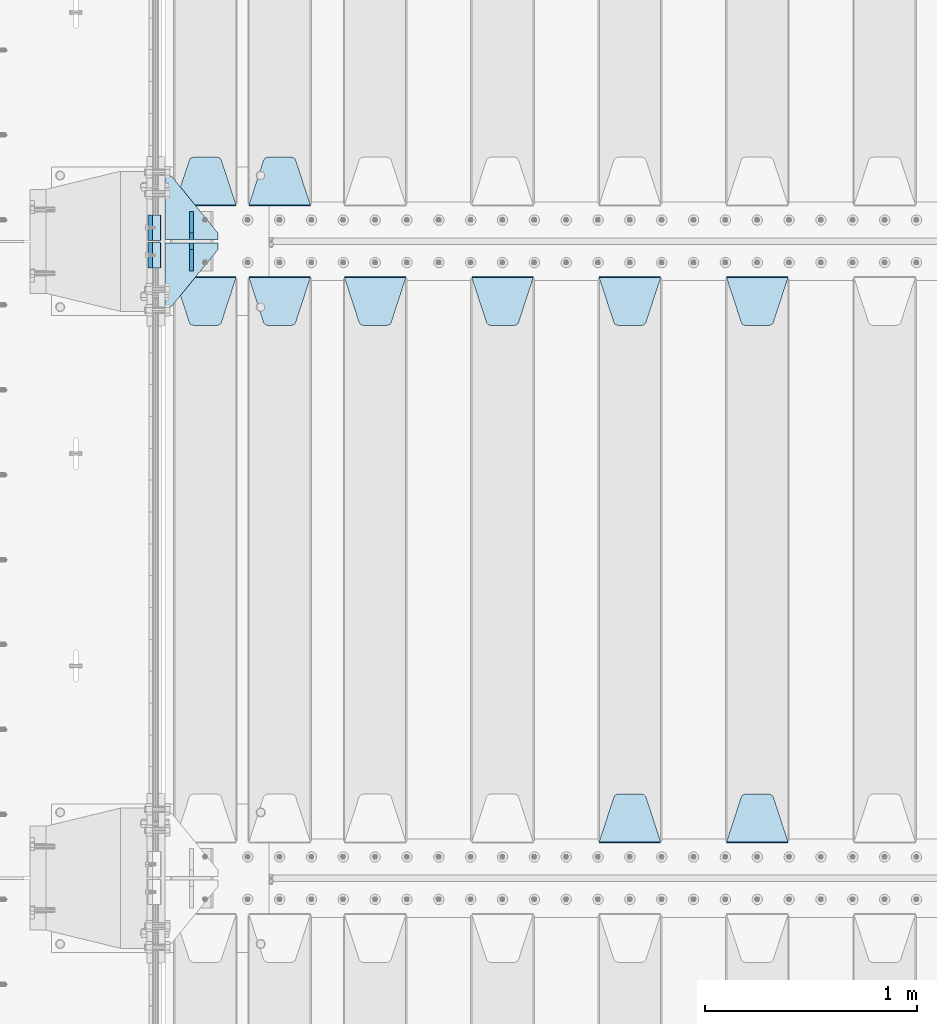
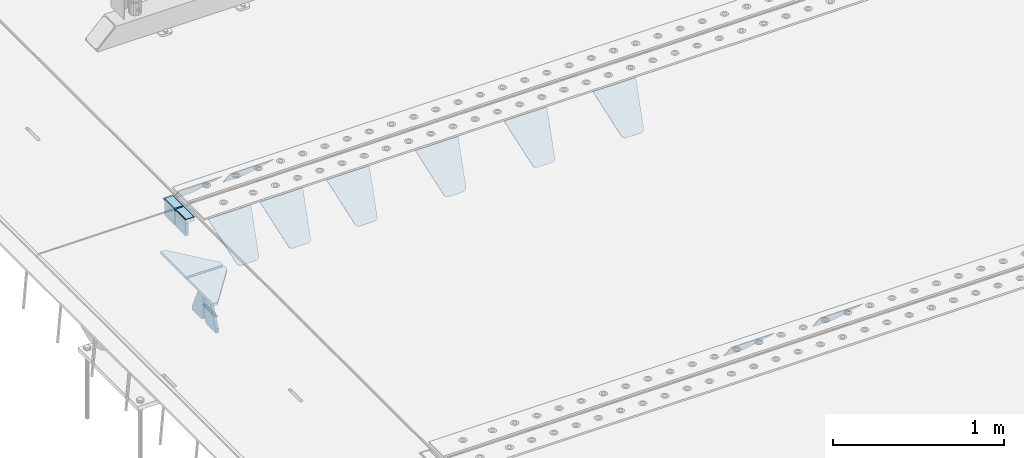
# One storey, part 200 of 247: 18 plates.
"""IFC2X3 building model written with IfcOpenShell, lengths in millimetres."""

from ifc_helpers import new_model, si_unit, frame, origin_with_axes, place, context, subcontext, project, spatial, faceted_brep, material, type_object, element, save


model = new_model("IFC2X3")

# Units and contexts
model_context = context("Model", 3, precision=1e-05, world=origin_with_axes())
body_context = subcontext(model_context, "Body", "Model", "MODEL_VIEW")
ifc_project = project(units=[si_unit("LENGTHUNIT", "METRE", prefix="MILLI"), si_unit("AREAUNIT", "SQUARE_METRE"), si_unit("VOLUMEUNIT", "CUBIC_METRE"), si_unit("MASSUNIT", "GRAM", prefix="KILO"), si_unit("TIMEUNIT", "SECOND"), si_unit("PLANEANGLEUNIT", "RADIAN"), si_unit("SOLIDANGLEUNIT", "STERADIAN"), si_unit("THERMODYNAMICTEMPERATUREUNIT", "DEGREE_CELSIUS"), si_unit("LUMINOUSINTENSITYUNIT", "LUMEN")], contexts=[model_context])

# Site, building, storey
site_placement = place(None, origin_with_axes())
site = spatial("IfcSite", under=ifc_project, at=site_placement, CompositionType="ELEMENT")
building_placement = place(site_placement, origin_with_axes())
building = spatial("IfcBuilding", under=site, at=building_placement, Name="Standard", CompositionType="ELEMENT")
storey_placement = place(building_placement, origin_with_axes())
storey = spatial("IfcBuildingStorey", under=building, at=storey_placement, Name="Undefined", CompositionType="ELEMENT", Elevation=0.0)

# Plates
ifc_material_1 = material()
plate_type_1 = type_object("IfcPlateType", PredefinedType="NOTDEFINED")
for number, where, z_axis, x_axis in (
    (1, (-9.99999993997335, 5935.0000004336, -16.0003868494704), (-1.0, 0.0, 0.0), (0.0, -4.95099999998473e-06, 0.999999999987744)),
    (2, (-10.0000000600267, 6065.00000043195, -15.999743219176), (-1.0, 0.0, 0.0), (0.0, -4.95099999998473e-06, 0.999999999987744)),
):
    element("IfcPlate", number, at=place(storey_placement, frame(where, z_axis=z_axis, x_axis=x_axis)), inside=storey, type_object=plate_type_1, material=ifc_material_1, context=body_context, shape_type="Brep", body=[
        faceted_brep([(0.0, -59.9999999999991, 0.0), (-0.000933120085690575, -60.0, 60.0), (-0.000933120085690575, 60.0, 60.0), (-3.5527136788005e-15, 60.0000000000005, 0.0), (24.9991450303709, -60.0, 60.0), (24.9991450303709, 60.0, 60.0), (26.544215218168, -60.0, 59.7552873850884), (26.544215218168, 60.0, 59.7552873850884), (27.9380461396139, -60.0, 59.0451032459123), (27.9380461396139, 60.0, 59.0451032459123), (29.0442025908961, -60.0, 57.9389639895784), (29.0442025908961, 60.0, 57.9389639895784), (29.7544083969366, -60.0, 56.5451441080361), (29.7544083969366, 60.0, 56.5451441080361), (29.9991450297669, -60.0, 55.0000777244568), (29.9991450297668, 60.0, 55.0000777244568), (29.999922274335, -60.0, 5.00007772445704), (29.999922274335, 60.0, 5.00007772445704), (29.7552240705896, -60.0, 3.45497416452589), (29.7552240705896, 60.0, 3.45497416452589), (29.0450346578116, -60.0, 2.0611114669096), (29.0450346578116, 60.0, 2.06111146690959), (27.9388736885072, -60.0, 0.954933302319514), (27.9388736885072, 60.0, 0.954933302319514), (26.5450220308766, -60.0, 0.244722222183091), (26.5450220308766, 60.0, 0.244722222183089), (24.9999222749392, -60.0, 2.66453525910038e-13), (24.9999222749392, 60.0, 2.66453525910038e-13)], [[[0, 1, 2, 3]], [[1, 4, 5, 2]], [[4, 6, 7, 5]], [[6, 8, 9, 7]], [[8, 10, 11, 9]], [[10, 12, 13, 11]], [[12, 14, 15, 13]], [[14, 16, 17, 15]], [[16, 18, 19, 17]], [[18, 20, 21, 19]], [[20, 22, 23, 21]], [[22, 24, 25, 23]], [[24, 26, 27, 25]], [[26, 0, 3, 27]], [[5, 7, 9, 11, 13, 15, 17, 19, 21, 23, 25, 27, 3, 2]], [[26, 24, 22, 20, 18, 16, 14, 12, 10, 8, 6, 4, 1, 0]]]),
    ])
ifc_material_2 = material(Name="STEEL/S355N")
plate_type_2 = type_object("IfcPlateType", PredefinedType="NOTDEFINED")
for number, where, z_axis, x_axis in (
    (3, (-60.0, 5995.00044598306, -106.000711879208), (1.00000000012752e-09, -0.999999999987744, -4.95099999993936e-06), (0.0, -4.95099999998473e-06, 0.999999999987744)),
    (4, (-60.0, 6125.00044598126, -106.000068249326), (1.00000000012752e-09, -0.999999999987744, -4.95099999993936e-06), (0.0, -4.95099999998473e-06, 0.999999999987744)),
):
    element("IfcPlate", number, at=place(storey_placement, frame(where, z_axis=z_axis, x_axis=x_axis)), inside=storey, type_object=plate_type_2, material=ifc_material_2, context=body_context, shape_type="Brep", body=[
        faceted_brep([(-5.6843418860808e-14, -9.99999999999989, 3.5527136788005e-15), (4.32933688898629e-10, -10.0, 120.0), (4.32933688898629e-10, 10.0, 120.0), (-5.6843418860808e-14, 10.0000000000001, 3.5527136788005e-15), (90.0, -10.0, 120.0), (90.0, 10.0, 120.0), (90.0, -10.0, 1.09139364212751e-11), (90.0, 10.0, 1.09139364212751e-11)], [[[0, 1, 2, 3]], [[1, 4, 5, 2]], [[4, 6, 7, 5]], [[6, 0, 3, 7]], [[5, 7, 3, 2]], [[6, 4, 1, 0]]]),
    ])
plate_type_3 = type_object("IfcPlateType", PredefinedType="NOTDEFINED")
plate_1_placement = place(storey_placement, frame((2655.0, 5831.76776695594, -1.767766952965), z_axis=(0.0, -0.707106781186548, -0.707106781186547), x_axis=(1.0, 0.0, 0.0)))
element("IfcPlate", 5, at=plate_1_placement, inside=storey, type_object=plate_type_3, material=ifc_material_2, context=body_context, shape_type="Brep", body=[
    faceted_brep([(0.0, -2.49999999999909, 0.0), (69.345504679477, -2.5, 300.17173142483), (69.345504679477, 2.50000000000091, 300.171731424831), (0.0, 2.5, -9.09494701772928e-13), (70.9274061199576, -2.5, 304.897442415399), (70.9274061199576, 2.50000000000091, 304.8974424154), (73.3818627772307, -2.49999999999909, 309.234538108527), (73.3818627772307, 2.5, 309.234538108526), (76.6187032999551, -2.5, 313.023683126102), (76.6187032999551, 2.50000000000091, 313.023683126102), (80.5190132704993, -2.49999999999909, 316.125672595371), (80.5190132704993, 2.50000000000091, 316.125672595372), (84.9395038596849, -2.49999999999909, 318.426546230476), (84.9395038596849, 2.5, 318.426546230475), (89.7177759439219, -2.5, 319.841774983274), (89.7177759439219, 2.50000000000091, 319.841774983275), (94.678286292652, -2.5, 320.319366455077), (94.678286292652, 2.50000000000091, 320.319366455077), (195.321713707348, -2.5, 320.319366455077), (195.321713707348, 2.50000000000091, 320.319366455077), (200.282224056078, -2.5, 319.841774983274), (200.282224056078, 2.50000000000091, 319.841774983275), (205.060496140315, -2.5, 318.426546230475), (205.060496140315, 2.5, 318.426546230474), (209.480986729501, -2.49999999999818, 316.12567259537), (209.480986729501, 2.50000000000091, 316.12567259537), (213.381296700045, -2.5, 313.023683126101), (213.381296700045, 2.50000000000091, 313.023683126101), (216.618137222769, -2.5, 309.234538108525), (216.618137222769, 2.5, 309.234538108525), (219.072593880042, -2.49999999999909, 304.897442415398), (219.072593880042, 2.5, 304.897442415398), (220.654495320523, -2.5, 300.17173142483), (220.654495320523, 2.50000000000091, 300.171731424831), (290.0, -2.49999999999909, 0.0), (290.0, 2.5, -9.09494701772928e-13)], [[[0, 1, 2, 3]], [[1, 4, 5, 2]], [[4, 6, 7, 5]], [[6, 8, 9, 7]], [[8, 10, 11, 9]], [[10, 12, 13, 11]], [[12, 14, 15, 13]], [[14, 16, 17, 15]], [[16, 18, 19, 17]], [[18, 20, 21, 19]], [[20, 22, 23, 21]], [[22, 24, 25, 23]], [[24, 26, 27, 25]], [[26, 28, 29, 27]], [[28, 30, 31, 29]], [[30, 32, 33, 31]], [[32, 34, 35, 33]], [[34, 0, 3, 35]], [[5, 7, 9, 11, 13, 15, 17, 19, 21, 23, 25, 27, 29, 31, 33, 35, 3, 2]], [[34, 32, 30, 28, 26, 24, 22, 20, 18, 16, 14, 12, 10, 8, 6, 4, 1, 0]]]),
])
plate_2_placement = place(storey_placement, frame((2945.0, 3168.23223304703, -1.76776695296758), z_axis=(0.0, 0.707106781186548, -0.707106781186547), x_axis=(-1.0, 0.0, 0.0)))
element("IfcPlate", 6, at=plate_2_placement, inside=storey, type_object=plate_type_3, material=ifc_material_2, context=body_context, shape_type="Brep", body=[
    faceted_brep([(0.0, -2.49999999999909, 0.0), (69.345504679477, -2.5, 300.17173142483), (69.345504679477, 2.50000000000091, 300.171731424831), (0.0, 2.5, -9.09494701772928e-13), (70.9274061199576, -2.5, 304.897442415399), (70.9274061199576, 2.50000000000091, 304.8974424154), (73.3818627772307, -2.49999999999909, 309.234538108527), (73.3818627772307, 2.5, 309.234538108526), (76.6187032999551, -2.5, 313.023683126102), (76.6187032999551, 2.50000000000091, 313.023683126102), (80.5190132704993, -2.49999999999909, 316.125672595371), (80.5190132704993, 2.50000000000091, 316.125672595372), (84.9395038596849, -2.49999999999909, 318.426546230476), (84.9395038596849, 2.5, 318.426546230475), (89.7177759439219, -2.5, 319.841774983274), (89.7177759439219, 2.50000000000091, 319.841774983275), (94.678286292652, -2.5, 320.319366455077), (94.678286292652, 2.50000000000091, 320.319366455077), (195.321713707348, -2.5, 320.319366455077), (195.321713707348, 2.50000000000091, 320.319366455077), (200.282224056078, -2.5, 319.841774983274), (200.282224056078, 2.50000000000091, 319.841774983275), (205.060496140315, -2.5, 318.426546230475), (205.060496140315, 2.5, 318.426546230474), (209.480986729501, -2.49999999999818, 316.12567259537), (209.480986729501, 2.50000000000091, 316.12567259537), (213.381296700045, -2.5, 313.023683126101), (213.381296700045, 2.50000000000091, 313.023683126101), (216.618137222769, -2.5, 309.234538108525), (216.618137222769, 2.5, 309.234538108525), (219.072593880042, -2.49999999999909, 304.897442415398), (219.072593880042, 2.5, 304.897442415398), (220.654495320523, -2.5, 300.17173142483), (220.654495320523, 2.50000000000091, 300.171731424831), (290.0, -2.49999999999909, 0.0), (290.0, 2.5, -9.09494701772928e-13)], [[[0, 1, 2, 3]], [[1, 4, 5, 2]], [[4, 6, 7, 5]], [[6, 8, 9, 7]], [[8, 10, 11, 9]], [[10, 12, 13, 11]], [[12, 14, 15, 13]], [[14, 16, 17, 15]], [[16, 18, 19, 17]], [[18, 20, 21, 19]], [[20, 22, 23, 21]], [[22, 24, 25, 23]], [[24, 26, 27, 25]], [[26, 28, 29, 27]], [[28, 30, 31, 29]], [[30, 32, 33, 31]], [[32, 34, 35, 33]], [[34, 0, 3, 35]], [[5, 7, 9, 11, 13, 15, 17, 19, 21, 23, 25, 27, 29, 31, 33, 35, 3, 2]], [[34, 32, 30, 28, 26, 24, 22, 20, 18, 16, 14, 12, 10, 8, 6, 4, 1, 0]]]),
])
plate_3_placement = place(storey_placement, frame((2055.0, 5831.76776695594, -1.767766952965), z_axis=(0.0, -0.707106781186548, -0.707106781186547), x_axis=(1.0, 0.0, 0.0)))
element("IfcPlate", 7, at=plate_3_placement, inside=storey, type_object=plate_type_3, material=ifc_material_2, context=body_context, shape_type="Brep", body=[
    faceted_brep([(0.0, -2.49999999999909, 0.0), (69.345504679477, -2.5, 300.17173142483), (69.345504679477, 2.50000000000091, 300.171731424831), (0.0, 2.5, -9.09494701772928e-13), (70.9274061199576, -2.5, 304.897442415399), (70.9274061199576, 2.50000000000091, 304.8974424154), (73.3818627772307, -2.49999999999909, 309.234538108527), (73.3818627772307, 2.5, 309.234538108526), (76.6187032999551, -2.5, 313.023683126102), (76.6187032999551, 2.50000000000091, 313.023683126102), (80.5190132704993, -2.49999999999909, 316.125672595371), (80.5190132704993, 2.50000000000091, 316.125672595372), (84.9395038596849, -2.49999999999909, 318.426546230476), (84.9395038596849, 2.5, 318.426546230475), (89.7177759439219, -2.5, 319.841774983274), (89.7177759439219, 2.50000000000091, 319.841774983275), (94.678286292652, -2.5, 320.319366455077), (94.678286292652, 2.50000000000091, 320.319366455077), (195.321713707348, -2.5, 320.319366455077), (195.321713707348, 2.50000000000091, 320.319366455077), (200.282224056078, -2.5, 319.841774983274), (200.282224056078, 2.50000000000091, 319.841774983275), (205.060496140315, -2.5, 318.426546230475), (205.060496140315, 2.5, 318.426546230474), (209.480986729501, -2.49999999999818, 316.12567259537), (209.480986729501, 2.50000000000091, 316.12567259537), (213.381296700045, -2.5, 313.023683126101), (213.381296700045, 2.50000000000091, 313.023683126101), (216.618137222769, -2.5, 309.234538108525), (216.618137222769, 2.5, 309.234538108525), (219.072593880042, -2.49999999999909, 304.897442415398), (219.072593880042, 2.5, 304.897442415398), (220.654495320523, -2.5, 300.17173142483), (220.654495320523, 2.50000000000091, 300.171731424831), (290.0, -2.49999999999909, 0.0), (290.0, 2.5, -9.09494701772928e-13)], [[[0, 1, 2, 3]], [[1, 4, 5, 2]], [[4, 6, 7, 5]], [[6, 8, 9, 7]], [[8, 10, 11, 9]], [[10, 12, 13, 11]], [[12, 14, 15, 13]], [[14, 16, 17, 15]], [[16, 18, 19, 17]], [[18, 20, 21, 19]], [[20, 22, 23, 21]], [[22, 24, 25, 23]], [[24, 26, 27, 25]], [[26, 28, 29, 27]], [[28, 30, 31, 29]], [[30, 32, 33, 31]], [[32, 34, 35, 33]], [[34, 0, 3, 35]], [[5, 7, 9, 11, 13, 15, 17, 19, 21, 23, 25, 27, 29, 31, 33, 35, 3, 2]], [[34, 32, 30, 28, 26, 24, 22, 20, 18, 16, 14, 12, 10, 8, 6, 4, 1, 0]]]),
])
plate_4_placement = place(storey_placement, frame((2345.0, 3168.23223304703, -1.76776695296758), z_axis=(0.0, 0.707106781186548, -0.707106781186547), x_axis=(-1.0, 0.0, 0.0)))
element("IfcPlate", 8, at=plate_4_placement, inside=storey, type_object=plate_type_3, material=ifc_material_2, context=body_context, shape_type="Brep", body=[
    faceted_brep([(0.0, -2.49999999999909, 0.0), (69.345504679477, -2.5, 300.17173142483), (69.345504679477, 2.50000000000091, 300.171731424831), (0.0, 2.5, -9.09494701772928e-13), (70.9274061199576, -2.5, 304.897442415399), (70.9274061199576, 2.50000000000091, 304.8974424154), (73.3818627772307, -2.49999999999909, 309.234538108527), (73.3818627772307, 2.5, 309.234538108526), (76.6187032999551, -2.5, 313.023683126102), (76.6187032999551, 2.50000000000091, 313.023683126102), (80.5190132704993, -2.49999999999909, 316.125672595371), (80.5190132704993, 2.50000000000091, 316.125672595372), (84.9395038596849, -2.49999999999909, 318.426546230476), (84.9395038596849, 2.5, 318.426546230475), (89.7177759439219, -2.5, 319.841774983274), (89.7177759439219, 2.50000000000091, 319.841774983275), (94.678286292652, -2.5, 320.319366455077), (94.678286292652, 2.50000000000091, 320.319366455077), (195.321713707348, -2.5, 320.319366455077), (195.321713707348, 2.50000000000091, 320.319366455077), (200.282224056078, -2.5, 319.841774983274), (200.282224056078, 2.50000000000091, 319.841774983275), (205.060496140315, -2.5, 318.426546230475), (205.060496140315, 2.5, 318.426546230474), (209.480986729501, -2.49999999999818, 316.12567259537), (209.480986729501, 2.50000000000091, 316.12567259537), (213.381296700045, -2.5, 313.023683126101), (213.381296700045, 2.50000000000091, 313.023683126101), (216.618137222769, -2.5, 309.234538108525), (216.618137222769, 2.5, 309.234538108525), (219.072593880042, -2.49999999999909, 304.897442415398), (219.072593880042, 2.5, 304.897442415398), (220.654495320523, -2.5, 300.17173142483), (220.654495320523, 2.50000000000091, 300.171731424831), (290.0, -2.49999999999909, 0.0), (290.0, 2.5, -9.09494701772928e-13)], [[[0, 1, 2, 3]], [[1, 4, 5, 2]], [[4, 6, 7, 5]], [[6, 8, 9, 7]], [[8, 10, 11, 9]], [[10, 12, 13, 11]], [[12, 14, 15, 13]], [[14, 16, 17, 15]], [[16, 18, 19, 17]], [[18, 20, 21, 19]], [[20, 22, 23, 21]], [[22, 24, 25, 23]], [[24, 26, 27, 25]], [[26, 28, 29, 27]], [[28, 30, 31, 29]], [[30, 32, 33, 31]], [[32, 34, 35, 33]], [[34, 0, 3, 35]], [[5, 7, 9, 11, 13, 15, 17, 19, 21, 23, 25, 27, 29, 31, 33, 35, 3, 2]], [[34, 32, 30, 28, 26, 24, 22, 20, 18, 16, 14, 12, 10, 8, 6, 4, 1, 0]]]),
])
plate_5_placement = place(storey_placement, frame((1455.0, 5831.76776695594, -1.767766952965), z_axis=(0.0, -0.707106781186548, -0.707106781186547), x_axis=(1.0, 0.0, 0.0)))
element("IfcPlate", 9, at=plate_5_placement, inside=storey, type_object=plate_type_3, material=ifc_material_2, context=body_context, shape_type="Brep", body=[
    faceted_brep([(0.0, -2.49999999999909, 0.0), (69.345504679477, -2.5, 300.17173142483), (69.345504679477, 2.50000000000091, 300.171731424831), (0.0, 2.5, -9.09494701772928e-13), (70.9274061199576, -2.5, 304.897442415399), (70.9274061199576, 2.50000000000091, 304.8974424154), (73.3818627772307, -2.49999999999909, 309.234538108527), (73.3818627772307, 2.5, 309.234538108526), (76.6187032999551, -2.5, 313.023683126102), (76.6187032999551, 2.50000000000091, 313.023683126102), (80.5190132704993, -2.49999999999909, 316.125672595371), (80.5190132704993, 2.50000000000091, 316.125672595372), (84.9395038596849, -2.49999999999909, 318.426546230476), (84.9395038596849, 2.5, 318.426546230475), (89.7177759439219, -2.5, 319.841774983274), (89.7177759439219, 2.50000000000091, 319.841774983275), (94.678286292652, -2.5, 320.319366455077), (94.678286292652, 2.50000000000091, 320.319366455077), (195.321713707348, -2.5, 320.319366455077), (195.321713707348, 2.50000000000091, 320.319366455077), (200.282224056078, -2.5, 319.841774983274), (200.282224056078, 2.50000000000091, 319.841774983275), (205.060496140315, -2.5, 318.426546230475), (205.060496140315, 2.5, 318.426546230474), (209.480986729501, -2.49999999999818, 316.12567259537), (209.480986729501, 2.50000000000091, 316.12567259537), (213.381296700045, -2.5, 313.023683126101), (213.381296700045, 2.50000000000091, 313.023683126101), (216.618137222769, -2.5, 309.234538108525), (216.618137222769, 2.5, 309.234538108525), (219.072593880042, -2.49999999999909, 304.897442415398), (219.072593880042, 2.5, 304.897442415398), (220.654495320523, -2.5, 300.17173142483), (220.654495320523, 2.50000000000091, 300.171731424831), (290.0, -2.49999999999909, 0.0), (290.0, 2.5, -9.09494701772928e-13)], [[[0, 1, 2, 3]], [[1, 4, 5, 2]], [[4, 6, 7, 5]], [[6, 8, 9, 7]], [[8, 10, 11, 9]], [[10, 12, 13, 11]], [[12, 14, 15, 13]], [[14, 16, 17, 15]], [[16, 18, 19, 17]], [[18, 20, 21, 19]], [[20, 22, 23, 21]], [[22, 24, 25, 23]], [[24, 26, 27, 25]], [[26, 28, 29, 27]], [[28, 30, 31, 29]], [[30, 32, 33, 31]], [[32, 34, 35, 33]], [[34, 0, 3, 35]], [[5, 7, 9, 11, 13, 15, 17, 19, 21, 23, 25, 27, 29, 31, 33, 35, 3, 2]], [[34, 32, 30, 28, 26, 24, 22, 20, 18, 16, 14, 12, 10, 8, 6, 4, 1, 0]]]),
])
plate_6_placement = place(storey_placement, frame((855.0, 5831.76776695594, -1.767766952965), z_axis=(0.0, -0.707106781186548, -0.707106781186547), x_axis=(1.0, 0.0, 0.0)))
element("IfcPlate", 10, at=plate_6_placement, inside=storey, type_object=plate_type_3, material=ifc_material_2, context=body_context, shape_type="Brep", body=[
    faceted_brep([(0.0, -2.49999999999909, 0.0), (69.345504679477, -2.5, 300.17173142483), (69.345504679477, 2.50000000000091, 300.171731424831), (0.0, 2.5, -9.09494701772928e-13), (70.9274061199576, -2.5, 304.897442415399), (70.9274061199576, 2.50000000000091, 304.8974424154), (73.3818627772307, -2.49999999999909, 309.234538108527), (73.3818627772307, 2.5, 309.234538108526), (76.6187032999551, -2.5, 313.023683126102), (76.6187032999551, 2.50000000000091, 313.023683126102), (80.5190132704993, -2.49999999999909, 316.125672595371), (80.5190132704993, 2.50000000000091, 316.125672595372), (84.9395038596849, -2.49999999999909, 318.426546230476), (84.9395038596849, 2.5, 318.426546230475), (89.7177759439219, -2.5, 319.841774983274), (89.7177759439219, 2.50000000000091, 319.841774983275), (94.678286292652, -2.5, 320.319366455077), (94.678286292652, 2.50000000000091, 320.319366455077), (195.321713707348, -2.5, 320.319366455077), (195.321713707348, 2.50000000000091, 320.319366455077), (200.282224056078, -2.5, 319.841774983274), (200.282224056078, 2.50000000000091, 319.841774983275), (205.060496140315, -2.5, 318.426546230475), (205.060496140315, 2.5, 318.426546230474), (209.480986729501, -2.49999999999818, 316.12567259537), (209.480986729501, 2.50000000000091, 316.12567259537), (213.381296700045, -2.5, 313.023683126101), (213.381296700045, 2.50000000000091, 313.023683126101), (216.618137222769, -2.5, 309.234538108525), (216.618137222769, 2.5, 309.234538108525), (219.072593880042, -2.49999999999909, 304.897442415398), (219.072593880042, 2.5, 304.897442415398), (220.654495320523, -2.5, 300.17173142483), (220.654495320523, 2.50000000000091, 300.171731424831), (290.0, -2.49999999999909, 0.0), (290.0, 2.5, -9.09494701772928e-13)], [[[0, 1, 2, 3]], [[1, 4, 5, 2]], [[4, 6, 7, 5]], [[6, 8, 9, 7]], [[8, 10, 11, 9]], [[10, 12, 13, 11]], [[12, 14, 15, 13]], [[14, 16, 17, 15]], [[16, 18, 19, 17]], [[18, 20, 21, 19]], [[20, 22, 23, 21]], [[22, 24, 25, 23]], [[24, 26, 27, 25]], [[26, 28, 29, 27]], [[28, 30, 31, 29]], [[30, 32, 33, 31]], [[32, 34, 35, 33]], [[34, 0, 3, 35]], [[5, 7, 9, 11, 13, 15, 17, 19, 21, 23, 25, 27, 29, 31, 33, 35, 3, 2]], [[34, 32, 30, 28, 26, 24, 22, 20, 18, 16, 14, 12, 10, 8, 6, 4, 1, 0]]]),
])
plate_7_placement = place(storey_placement, frame((405.0, 5831.76776695594, -1.767766952965), z_axis=(0.0, -0.707106781186548, -0.707106781186547), x_axis=(1.0, 0.0, 0.0)))
element("IfcPlate", 11, at=plate_7_placement, inside=storey, type_object=plate_type_3, material=ifc_material_2, context=body_context, shape_type="Brep", body=[
    faceted_brep([(0.0, -2.49999999999909, 0.0), (69.345504679477, -2.5, 300.17173142483), (69.345504679477, 2.50000000000091, 300.171731424831), (0.0, 2.5, -9.09494701772928e-13), (70.9274061199576, -2.5, 304.897442415399), (70.9274061199576, 2.50000000000091, 304.8974424154), (73.3818627772307, -2.49999999999909, 309.234538108527), (73.3818627772307, 2.5, 309.234538108526), (76.6187032999551, -2.5, 313.023683126102), (76.6187032999551, 2.50000000000091, 313.023683126102), (80.5190132704993, -2.49999999999909, 316.125672595371), (80.5190132704993, 2.50000000000091, 316.125672595372), (84.9395038596849, -2.49999999999909, 318.426546230476), (84.9395038596849, 2.5, 318.426546230475), (89.7177759439219, -2.5, 319.841774983274), (89.7177759439219, 2.50000000000091, 319.841774983275), (94.678286292652, -2.5, 320.319366455077), (94.678286292652, 2.50000000000091, 320.319366455077), (195.321713707348, -2.5, 320.319366455077), (195.321713707348, 2.50000000000091, 320.319366455077), (200.282224056078, -2.5, 319.841774983274), (200.282224056078, 2.50000000000091, 319.841774983275), (205.060496140315, -2.5, 318.426546230475), (205.060496140315, 2.5, 318.426546230474), (209.480986729501, -2.49999999999818, 316.12567259537), (209.480986729501, 2.50000000000091, 316.12567259537), (213.381296700045, -2.5, 313.023683126101), (213.381296700045, 2.50000000000091, 313.023683126101), (216.618137222769, -2.5, 309.234538108525), (216.618137222769, 2.5, 309.234538108525), (219.072593880042, -2.49999999999909, 304.897442415398), (219.072593880042, 2.5, 304.897442415398), (220.654495320523, -2.5, 300.17173142483), (220.654495320523, 2.50000000000091, 300.171731424831), (290.0, -2.49999999999909, 0.0), (290.0, 2.5, -9.09494701772928e-13)], [[[0, 1, 2, 3]], [[1, 4, 5, 2]], [[4, 6, 7, 5]], [[6, 8, 9, 7]], [[8, 10, 11, 9]], [[10, 12, 13, 11]], [[12, 14, 15, 13]], [[14, 16, 17, 15]], [[16, 18, 19, 17]], [[18, 20, 21, 19]], [[20, 22, 23, 21]], [[22, 24, 25, 23]], [[24, 26, 27, 25]], [[26, 28, 29, 27]], [[28, 30, 31, 29]], [[30, 32, 33, 31]], [[32, 34, 35, 33]], [[34, 0, 3, 35]], [[5, 7, 9, 11, 13, 15, 17, 19, 21, 23, 25, 27, 29, 31, 33, 35, 3, 2]], [[34, 32, 30, 28, 26, 24, 22, 20, 18, 16, 14, 12, 10, 8, 6, 4, 1, 0]]]),
])
plate_8_placement = place(storey_placement, frame((695.0, 6168.23223304703, -1.76776695296758), z_axis=(0.0, 0.707106781186548, -0.707106781186547), x_axis=(-1.0, 0.0, 0.0)))
element("IfcPlate", 12, at=plate_8_placement, inside=storey, type_object=plate_type_3, material=ifc_material_2, context=body_context, shape_type="Brep", body=[
    faceted_brep([(0.0, -2.49999999999909, 0.0), (69.345504679477, -2.5, 300.17173142483), (69.345504679477, 2.50000000000091, 300.171731424831), (0.0, 2.5, -9.09494701772928e-13), (70.9274061199576, -2.5, 304.897442415399), (70.9274061199576, 2.50000000000091, 304.8974424154), (73.3818627772307, -2.49999999999909, 309.234538108527), (73.3818627772307, 2.5, 309.234538108526), (76.6187032999551, -2.5, 313.023683126102), (76.6187032999551, 2.50000000000091, 313.023683126102), (80.5190132704993, -2.49999999999909, 316.125672595371), (80.5190132704993, 2.50000000000091, 316.125672595372), (84.9395038596849, -2.49999999999909, 318.426546230476), (84.9395038596849, 2.5, 318.426546230475), (89.7177759439219, -2.5, 319.841774983274), (89.7177759439219, 2.50000000000091, 319.841774983275), (94.678286292652, -2.5, 320.319366455077), (94.678286292652, 2.50000000000091, 320.319366455077), (195.321713707348, -2.5, 320.319366455077), (195.321713707348, 2.50000000000091, 320.319366455077), (200.282224056078, -2.5, 319.841774983274), (200.282224056078, 2.50000000000091, 319.841774983275), (205.060496140315, -2.5, 318.426546230475), (205.060496140315, 2.5, 318.426546230474), (209.480986729501, -2.49999999999818, 316.12567259537), (209.480986729501, 2.50000000000091, 316.12567259537), (213.381296700045, -2.5, 313.023683126101), (213.381296700045, 2.50000000000091, 313.023683126101), (216.618137222769, -2.5, 309.234538108525), (216.618137222769, 2.5, 309.234538108525), (219.072593880042, -2.49999999999909, 304.897442415398), (219.072593880042, 2.5, 304.897442415398), (220.654495320523, -2.5, 300.17173142483), (220.654495320523, 2.50000000000091, 300.171731424831), (290.0, -2.49999999999909, 0.0), (290.0, 2.5, -9.09494701772928e-13)], [[[0, 1, 2, 3]], [[1, 4, 5, 2]], [[4, 6, 7, 5]], [[6, 8, 9, 7]], [[8, 10, 11, 9]], [[10, 12, 13, 11]], [[12, 14, 15, 13]], [[14, 16, 17, 15]], [[16, 18, 19, 17]], [[18, 20, 21, 19]], [[20, 22, 23, 21]], [[22, 24, 25, 23]], [[24, 26, 27, 25]], [[26, 28, 29, 27]], [[28, 30, 31, 29]], [[30, 32, 33, 31]], [[32, 34, 35, 33]], [[34, 0, 3, 35]], [[5, 7, 9, 11, 13, 15, 17, 19, 21, 23, 25, 27, 29, 31, 33, 35, 3, 2]], [[34, 32, 30, 28, 26, 24, 22, 20, 18, 16, 14, 12, 10, 8, 6, 4, 1, 0]]]),
])
plate_9_placement = place(storey_placement, frame((345.0, 6168.23223304703, -1.76776695296758), z_axis=(0.0, 0.707106781186548, -0.707106781186547), x_axis=(-1.0, 0.0, 0.0)))
element("IfcPlate", 13, at=plate_9_placement, inside=storey, type_object=plate_type_3, material=ifc_material_2, context=body_context, shape_type="Brep", body=[
    faceted_brep([(0.0, -2.49999999999909, 0.0), (69.345504679477, -2.5, 300.17173142483), (69.345504679477, 2.50000000000091, 300.171731424831), (0.0, 2.5, -9.09494701772928e-13), (70.9274061199576, -2.5, 304.897442415399), (70.9274061199576, 2.50000000000091, 304.8974424154), (73.3818627772307, -2.49999999999909, 309.234538108527), (73.3818627772307, 2.5, 309.234538108526), (76.6187032999551, -2.5, 313.023683126102), (76.6187032999551, 2.50000000000091, 313.023683126102), (80.5190132704993, -2.49999999999909, 316.125672595371), (80.5190132704993, 2.50000000000091, 316.125672595372), (84.9395038596849, -2.49999999999909, 318.426546230476), (84.9395038596849, 2.5, 318.426546230475), (89.7177759439219, -2.5, 319.841774983274), (89.7177759439219, 2.50000000000091, 319.841774983275), (94.678286292652, -2.5, 320.319366455077), (94.678286292652, 2.50000000000091, 320.319366455077), (195.321713707348, -2.5, 320.319366455077), (195.321713707348, 2.50000000000091, 320.319366455077), (200.282224056078, -2.5, 319.841774983274), (200.282224056078, 2.50000000000091, 319.841774983275), (205.060496140315, -2.5, 318.426546230475), (205.060496140315, 2.5, 318.426546230474), (209.480986729501, -2.49999999999818, 316.12567259537), (209.480986729501, 2.50000000000091, 316.12567259537), (213.381296700045, -2.5, 313.023683126101), (213.381296700045, 2.50000000000091, 313.023683126101), (216.618137222769, -2.5, 309.234538108525), (216.618137222769, 2.5, 309.234538108525), (219.072593880042, -2.49999999999909, 304.897442415398), (219.072593880042, 2.5, 304.897442415398), (220.654495320523, -2.5, 300.17173142483), (220.654495320523, 2.50000000000091, 300.171731424831), (290.0, -2.49999999999909, 0.0), (290.0, 2.5, -9.09494701772928e-13)], [[[0, 1, 2, 3]], [[1, 4, 5, 2]], [[4, 6, 7, 5]], [[6, 8, 9, 7]], [[8, 10, 11, 9]], [[10, 12, 13, 11]], [[12, 14, 15, 13]], [[14, 16, 17, 15]], [[16, 18, 19, 17]], [[18, 20, 21, 19]], [[20, 22, 23, 21]], [[22, 24, 25, 23]], [[24, 26, 27, 25]], [[26, 28, 29, 27]], [[28, 30, 31, 29]], [[30, 32, 33, 31]], [[32, 34, 35, 33]], [[34, 0, 3, 35]], [[5, 7, 9, 11, 13, 15, 17, 19, 21, 23, 25, 27, 29, 31, 33, 35, 3, 2]], [[34, 32, 30, 28, 26, 24, 22, 20, 18, 16, 14, 12, 10, 8, 6, 4, 1, 0]]]),
])
plate_10_placement = place(storey_placement, frame((55.0, 5831.76776695594, -1.767766952965), z_axis=(0.0, -0.707106781186548, -0.707106781186547), x_axis=(1.0, 0.0, 0.0)))
element("IfcPlate", 14, at=plate_10_placement, inside=storey, type_object=plate_type_3, material=ifc_material_2, context=body_context, shape_type="Brep", body=[
    faceted_brep([(0.0, -2.49999999999909, 0.0), (69.345504679477, -2.5, 300.17173142483), (69.345504679477, 2.50000000000091, 300.171731424831), (0.0, 2.5, -9.09494701772928e-13), (70.9274061199576, -2.5, 304.897442415399), (70.9274061199576, 2.50000000000091, 304.8974424154), (73.3818627772307, -2.49999999999909, 309.234538108527), (73.3818627772307, 2.5, 309.234538108526), (76.6187032999551, -2.5, 313.023683126102), (76.6187032999551, 2.50000000000091, 313.023683126102), (80.5190132704993, -2.49999999999909, 316.125672595371), (80.5190132704993, 2.50000000000091, 316.125672595372), (84.9395038596849, -2.49999999999909, 318.426546230476), (84.9395038596849, 2.5, 318.426546230475), (89.7177759439219, -2.5, 319.841774983274), (89.7177759439219, 2.50000000000091, 319.841774983275), (94.678286292652, -2.5, 320.319366455077), (94.678286292652, 2.50000000000091, 320.319366455077), (195.321713707348, -2.5, 320.319366455077), (195.321713707348, 2.50000000000091, 320.319366455077), (200.282224056078, -2.5, 319.841774983274), (200.282224056078, 2.50000000000091, 319.841774983275), (205.060496140315, -2.5, 318.426546230475), (205.060496140315, 2.5, 318.426546230474), (209.480986729501, -2.49999999999818, 316.12567259537), (209.480986729501, 2.50000000000091, 316.12567259537), (213.381296700045, -2.5, 313.023683126101), (213.381296700045, 2.50000000000091, 313.023683126101), (216.618137222769, -2.5, 309.234538108525), (216.618137222769, 2.5, 309.234538108525), (219.072593880042, -2.49999999999909, 304.897442415398), (219.072593880042, 2.5, 304.897442415398), (220.654495320523, -2.5, 300.17173142483), (220.654495320523, 2.50000000000091, 300.171731424831), (290.0, -2.49999999999909, 0.0), (290.0, 2.5, -9.09494701772928e-13)], [[[0, 1, 2, 3]], [[1, 4, 5, 2]], [[4, 6, 7, 5]], [[6, 8, 9, 7]], [[8, 10, 11, 9]], [[10, 12, 13, 11]], [[12, 14, 15, 13]], [[14, 16, 17, 15]], [[16, 18, 19, 17]], [[18, 20, 21, 19]], [[20, 22, 23, 21]], [[22, 24, 25, 23]], [[24, 26, 27, 25]], [[26, 28, 29, 27]], [[28, 30, 31, 29]], [[30, 32, 33, 31]], [[32, 34, 35, 33]], [[34, 0, 3, 35]], [[5, 7, 9, 11, 13, 15, 17, 19, 21, 23, 25, 27, 29, 31, 33, 35, 3, 2]], [[34, 32, 30, 28, 26, 24, 22, 20, 18, 16, 14, 12, 10, 8, 6, 4, 1, 0]]]),
])
plate_type_4 = type_object("IfcPlateType", PredefinedType="NOTDEFINED")
for number, where, z_axis, x_axis in (
    (15, (259.999999999996, 6008.0, -515.0), (0.0, 1.0, 0.0), (-1.0, 0.0, 0.0)),
    (16, (259.999999999996, 5992.0, -515.0), (0.0, -0.999999999999548, -9.5100000000016e-07), (-1.0, 0.0, 0.0)),
):
    element("IfcPlate", number, at=place(storey_placement, frame(where, z_axis=z_axis, x_axis=x_axis)), inside=storey, type_object=plate_type_4, material=ifc_material_2, context=body_context, shape_type="Brep", body=[
        faceted_brep([(-5.6843418860808e-14, -9.99999999999989, 3.5527136788005e-15), (0.0, -10.0, 30.0), (0.0, 10.0, 30.0), (-5.6843418860808e-14, 10.0000000000001, 3.5527136788005e-15), (220.0, -10.0, 300.0), (220.0, 10.0, 300.0), (250.0, -10.0, 300.0), (250.0, 10.0, 300.0), (250.0, -10.0, 0.0), (250.0, 10.0, 0.0)], [[[0, 1, 2, 3]], [[1, 4, 5, 2]], [[4, 6, 7, 5]], [[6, 8, 9, 7]], [[8, 0, 3, 9]], [[5, 7, 9, 3, 2]], [[8, 6, 4, 1, 0]]]),
    ])
plate_type_5 = type_object("IfcPlateType", PredefinedType="NOTDEFINED")
for number, where, z_axis, x_axis in (
    (17, (135.0, 6140.0, -860.0), (0.0, 0.0, 1.0), (0.0, -0.999999999999548, -9.5100000000016e-07)),
    (18, (135.0, 5860.0, -860.0), (0.0, 0.0, 1.0), (0.0, 1.0, 0.0)),
):
    element("IfcPlate", number, at=place(storey_placement, frame(where, z_axis=z_axis, x_axis=x_axis)), inside=storey, type_object=plate_type_5, material=ifc_material_2, context=body_context, shape_type="Brep", body=[
        faceted_brep([(-5.6843418860808e-14, -9.99999999999989, 3.5527136788005e-15), (0.0, -10.0, 30.0), (0.0, 10.0, 30.0), (-5.6843418860808e-14, 10.0000000000001, 3.5527136788005e-15), (102.0, -10.0, 250.0), (102.0, 10.0, 250.0), (132.0, -10.0, 250.0), (132.0, 10.0, 250.0), (132.0, -10.0, 30.0), (132.0, 10.0, 30.0), (131.544232590366, -10.0, 24.790554669992), (131.544232590366, 10.0, 24.790554669992), (130.190778623577, -10.0, 19.7393957002299), (130.190778623577, 10.0, 19.7393957002299), (127.980762113533, -10.0, 15.0), (127.980762113533, 10.0, 15.0), (124.981333293569, -10.0, 10.7163717094038), (124.981333293569, 10.0, 10.7163717094038), (121.283628290596, -10.0, 7.01866670643062), (121.283628290596, 10.0, 7.01866670643062), (117.0, -10.0, 4.01923788646684), (117.0, 10.0, 4.01923788646684), (112.26060429977, -10.0, 1.80922137642278), (112.26060429977, 10.0, 1.80922137642278), (107.209445330008, -10.0, 0.455767409633722), (107.209445330008, 10.0, 0.455767409633722), (102.0, -10.0, 0.0), (102.0, 10.0, 0.0)], [[[0, 1, 2, 3]], [[1, 4, 5, 2]], [[4, 6, 7, 5]], [[6, 8, 9, 7]], [[8, 10, 11, 9]], [[10, 12, 13, 11]], [[12, 14, 15, 13]], [[14, 16, 17, 15]], [[16, 18, 19, 17]], [[18, 20, 21, 19]], [[20, 22, 23, 21]], [[22, 24, 25, 23]], [[24, 26, 27, 25]], [[26, 0, 3, 27]], [[5, 7, 9, 11, 13, 15, 17, 19, 21, 23, 25, 27, 3, 2]], [[26, 24, 22, 20, 18, 16, 14, 12, 10, 8, 6, 4, 1, 0]]]),
    ])

save(model, "model.ifc")
